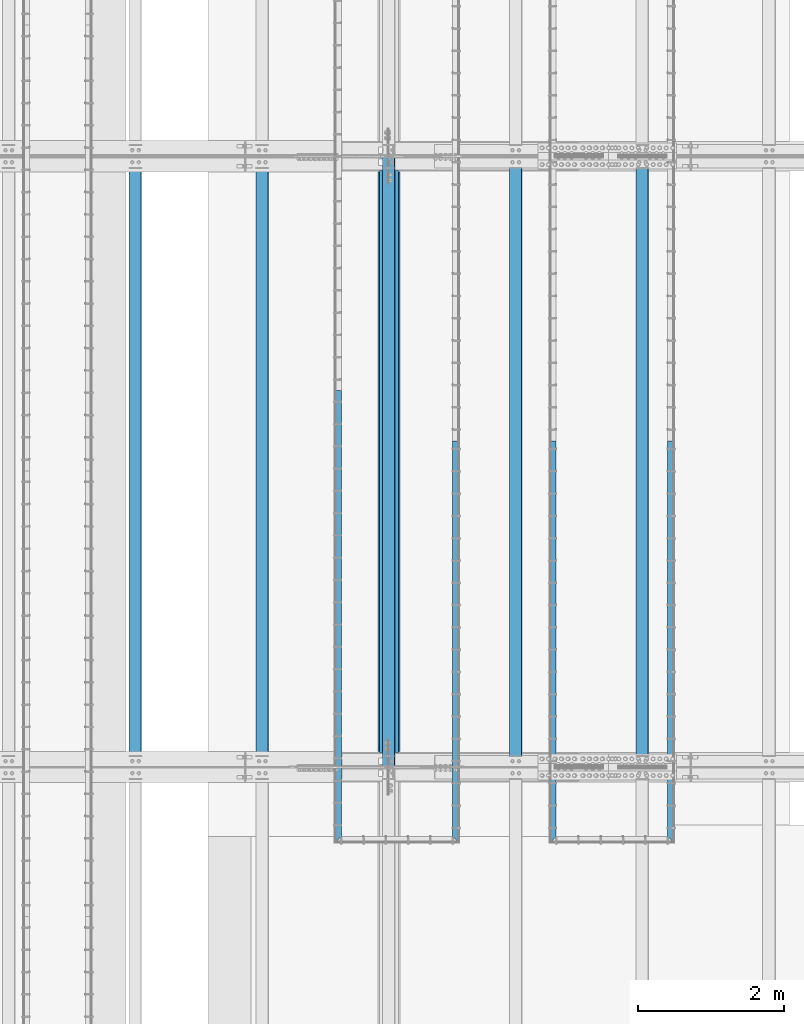
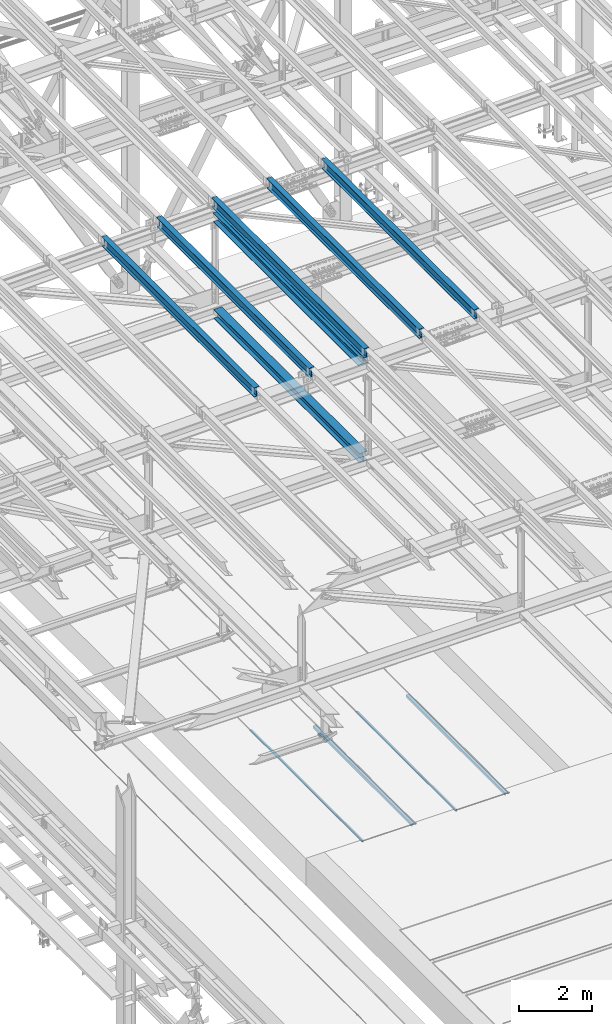
# One storey, part 1891 of 3843: 11 beams, 11 elements without a shape of their own.
"""IFC2X3 building model written with IfcOpenShell, lengths in millimetres."""

from ifc_helpers import new_model, si_unit, frame, origin_with_axes, place, context, subcontext, project, spatial, faceted_brep, material, type_object, element, aggregate, save


model = new_model("IFC2X3")

# Units and contexts
model_context = context("Model", 3, precision=1e-05, world=origin_with_axes())
body_context = subcontext(model_context, "Body", "Model", "MODEL_VIEW")
ifc_project = project(units=[si_unit("LENGTHUNIT", "METRE", prefix="MILLI"), si_unit("AREAUNIT", "SQUARE_METRE"), si_unit("VOLUMEUNIT", "CUBIC_METRE"), si_unit("MASSUNIT", "GRAM", prefix="KILO"), si_unit("TIMEUNIT", "SECOND"), si_unit("PLANEANGLEUNIT", "RADIAN"), si_unit("SOLIDANGLEUNIT", "STERADIAN"), si_unit("THERMODYNAMICTEMPERATUREUNIT", "DEGREE_CELSIUS"), si_unit("LUMINOUSINTENSITYUNIT", "LUMEN")], contexts=[model_context])

# Site, building, storey
site_placement = place(None, origin_with_axes())
site = spatial("IfcSite", under=ifc_project, at=site_placement, CompositionType="ELEMENT")
building_placement = place(site_placement, origin_with_axes())
building = spatial("IfcBuilding", under=site, at=building_placement, Name="Undefined", CompositionType="ELEMENT")
storey_placement = place(building_placement, origin_with_axes())
storey = spatial("IfcBuildingStorey", under=building, at=storey_placement, Name="Undefined", CompositionType="ELEMENT", Elevation=0.0)

# Assembly, beam
assembly_1_placement = place(storey_placement, origin_with_axes())
assembly_1 = element("IfcElementAssembly", 1, at=assembly_1_placement, inside=storey, Name="EMBED_ANGLE", AssemblyPlace="NOTDEFINED", PredefinedType="RIGID_FRAME")
ifc_material_1 = material(Name="STEEL/A36")
beam_type_1 = type_object("IfcBeamType", Name="L3-1/2X3-1/2X5/16", PredefinedType="NOTDEFINED")
beam_1_placement = place(assembly_1_placement, frame((52851.812, 71735.8227029324, 30410.15), z_axis=(0.0, 0.0, -1.0), x_axis=(0.0, -1.0, 0.0)))
beam_1 = element("IfcBeam", 2, at=beam_1_placement, type_object=beam_type_1, material=ifc_material_1, Name="EMBED_ANGLE", ObjectType="L3-1/2X3-1/2X5/16", context=body_context, shape_type="Brep", body=[
    faceted_brep([(-3.63797880709171e-12, 44.4499999999971, -44.4500000000007), (-3.63797880709171e-12, 44.4499999999971, 44.4500000000007), (5409.94572406872, 44.4500000096014, 44.4500000000007), (5409.94572406872, 44.4500000096014, -44.4500000000007), (-3.63797880709171e-12, 36.5124999999971, 44.4500000000007), (5417.88322413992, 36.5125000096305, 44.4500000000007), (-3.63797880709171e-12, 36.5124999999971, -36.5125000000007), (5417.88322413992, 36.5125000096305, -36.5125000000007), (3.63797880709171e-12, -44.4499999999971, -36.5125000000007), (5498.84572486606, -44.4499999902328, -36.5125000000007), (3.63797880709171e-12, -44.4499999999971, -44.4500000000007), (5498.84572486606, -44.4499999902328, -44.4500000000007)], [[[0, 1, 2, 3]], [[1, 4, 5, 2]], [[4, 6, 7, 5]], [[6, 8, 9, 7]], [[8, 10, 11, 9]], [[10, 0, 3, 11]], [[5, 7, 9, 11, 3, 2]], [[10, 8, 6, 4, 1, 0]]]),
])
aggregate(assembly_1, [beam_1])

assembly_2_placement = place(storey_placement, origin_with_axes())
assembly_2 = element("IfcElementAssembly", 3, at=assembly_2_placement, inside=storey, Name="EMBED_ANGLE", AssemblyPlace="NOTDEFINED", PredefinedType="RIGID_FRAME")
beam_2_placement = place(assembly_2_placement, frame((51238.9754185574, 66236.9769879788, 30410.15), z_axis=(0.0, 0.0, -1.0), x_axis=(0.0, 1.0, 0.0)))
beam_2 = element("IfcBeam", 4, at=beam_2_placement, type_object=beam_type_1, material=ifc_material_1, Name="EMBED_ANGLE", ObjectType="L3-1/2X3-1/2X5/16", context=body_context, shape_type="Brep", body=[
    faceted_brep([(88.8999999971129, 44.4500000000007, -44.4499999999971), (88.8999999965163, 44.4499999999971, 44.4500000000007), (5498.84566791133, 44.450000009776, 44.4500000000007), (5498.84566791133, 44.450000009776, -44.4500000000007), (80.9624999965163, 36.5124999999971, 44.4500000000007), (5498.84566791134, 36.512500009776, 44.4500000000007), (80.9624999971129, 36.5125000000007, -36.5124999999971), (5498.84566791134, 36.512500009776, -36.5125000000007), (3.63797880709171e-12, -44.4499999999971, -36.5125000000007), (5498.84572486606, -44.4499999902328, -36.5125000000007), (3.63797880709171e-12, -44.4499999999971, -44.4500000000007), (5498.84572486606, -44.4499999902328, -44.4500000000007)], [[[0, 1, 2, 3]], [[1, 4, 5, 2]], [[4, 6, 7, 5]], [[6, 8, 9, 7]], [[8, 10, 11, 9]], [[10, 0, 3, 11]], [[5, 7, 9, 11, 3, 2]], [[10, 8, 6, 4, 1, 0]]]),
])
aggregate(assembly_2, [beam_2])

assembly_3_placement = place(storey_placement, origin_with_axes())
assembly_3 = element("IfcElementAssembly", 5, at=assembly_3_placement, inside=storey, Name="EMBED_ANGLE", AssemblyPlace="NOTDEFINED", PredefinedType="RIGID_FRAME")
beam_3_placement = place(assembly_3_placement, frame((48298.8619292824, 66236.9765624103, 30410.15), z_axis=(0.0, 0.0, -1.0), x_axis=(0.0, 1.0, 0.0)))
beam_3 = element("IfcBeam", 6, at=beam_3_placement, type_object=beam_type_1, material=ifc_material_1, Name="EMBED_ANGLE", ObjectType="L3-1/2X3-1/2X5/16", context=body_context, shape_type="Brep", body=[
    faceted_brep([(88.9004566517688, 44.449999999968, -44.4500000000007), (88.9004566517688, 44.449999999968, 44.4500000000007), (6184.64645783564, 44.4499999976542, 44.4500000000007), (6184.64645783564, 44.4499999976542, -44.4500000000007), (80.9629571536643, 36.5124999999753, 44.4500000000007), (6184.64645783564, 36.5124999976542, 44.4500000000007), (80.9629571536643, 36.5124999999753, -36.5125000000007), (6184.64645783564, 36.5124999976542, -36.5125000000007), (0.000462273004814051, -44.4499999999971, -36.5125000000007), (6184.64645783561, -44.4500000023472, -36.5125000000007), (0.000462273004814051, -44.4499999999971, -44.4500000000007), (6184.64645783561, -44.4500000023472, -44.4500000000007)], [[[0, 1, 2, 3]], [[1, 4, 5, 2]], [[4, 6, 7, 5]], [[6, 8, 9, 7]], [[8, 10, 11, 9]], [[10, 0, 3, 11]], [[5, 7, 9, 11, 3, 2]], [[10, 8, 6, 4, 1, 0]]]),
])
aggregate(assembly_3, [beam_3])

assembly_4_placement = place(storey_placement, origin_with_axes())
assembly_4 = element("IfcElementAssembly", 7, at=assembly_4_placement, inside=storey, Name="EMBED_ANGLE", AssemblyPlace="NOTDEFINED", PredefinedType="RIGID_FRAME")
beam_4_placement = place(assembly_4_placement, frame((49911.7620576172, 71735.8227029324, 30410.15), z_axis=(0.0, 0.0, -1.0), x_axis=(0.0, -1.0, 0.0)))
beam_4 = element("IfcBeam", 8, at=beam_4_placement, type_object=beam_type_1, material=ifc_material_1, Name="EMBED_ANGLE", ObjectType="L3-1/2X3-1/2X5/16", context=body_context, shape_type="Brep", body=[
    faceted_brep([(-3.63797880709171e-12, 44.4499999999971, -44.4500000000007), (-3.63797880709171e-12, 44.4499999999971, 44.4500000000007), (5409.94572406872, 44.4500000096014, 44.4500000000007), (5409.94572406872, 44.4500000096014, -44.4500000000007), (-3.63797880709171e-12, 36.5124999999971, 44.4500000000007), (5417.88322413992, 36.5125000096305, 44.4500000000007), (-3.63797880709171e-12, 36.5124999999971, -36.5125000000007), (5417.88322413992, 36.5125000096305, -36.5125000000007), (3.63797880709171e-12, -44.4499999999971, -36.5125000000007), (5498.84572486606, -44.4499999902328, -36.5125000000007), (3.63797880709171e-12, -44.4499999999971, -44.4500000000007), (5498.84572486606, -44.4499999902328, -44.4500000000007)], [[[0, 1, 2, 3]], [[1, 4, 5, 2]], [[4, 6, 7, 5]], [[6, 8, 9, 7]], [[8, 10, 11, 9]], [[10, 0, 3, 11]], [[5, 7, 9, 11, 3, 2]], [[10, 8, 6, 4, 1, 0]]]),
])
aggregate(assembly_4, [beam_4])

assembly_5_placement = place(storey_placement, origin_with_axes())
assembly_5 = element("IfcElementAssembly", 9, at=assembly_5_placement, inside=storey, Name="BEAM", AssemblyPlace="NOTDEFINED", PredefinedType="RIGID_FRAME")
ifc_material_2 = material(Name="STEEL/A992")
beam_type_2 = type_object("IfcBeamType", Name="W12X26", PredefinedType="NOTDEFINED")
beam_5_placement = place(assembly_5_placement, frame((48993.3092623545, 67272.0720484337, 45897.8364992745), z_axis=(-0.0211520979474298, 0.0011058869996923, 0.999775657718454), x_axis=(0.0, 0.999999388232494, -0.001106135000257)))
beam_5 = element("IfcBeam", 10, at=beam_5_placement, type_object=beam_type_2, material=ifc_material_2, Name="BEAM", ObjectType="W12X26", context=body_context, shape_type="Brep", body=[
    faceted_brep([(12.7019392170769, 82.5499999998792, -155.574999999844), (12.6914056319511, 82.5499999998719, -146.049999999872), (8343.89650247573, 82.5500000000829, -146.050000009884), (8343.90703606085, 82.5500000000902, -155.575000009856), (12.6895484881388, 3.17500000001746, -146.04999999961), (8343.89464533191, 3.17500000022847, -146.050000009622), (12.3665185444988, 3.17499999995925, 146.049999999559), (8343.5716153883, 3.17500000017753, 146.049999989547), (12.3683756883402, 82.5499999998137, 146.049999999297), (8343.57347253212, 82.5500000000247, 146.049999989293), (12.3578421032144, 82.5499999998137, 155.574999999277), (8343.562938947, 82.550000000032, 155.574999989265), (12.353979244057, -82.5499999998865, 155.574999999815), (8343.55907608785, -82.5499999996755, 155.574999989803), (12.3645128291828, -82.5499999998792, 146.04999999985), (8343.56960967297, -82.5499999996682, 146.049999989838), (12.366369972995, -3.17500000002474, 146.049999999581), (8343.57146681679, -3.17499999981374, 146.049999989569), (12.6893999166205, -3.17499999996653, -146.049999999588), (8343.8944967604, -3.17499999975553, -146.0500000096), (12.6875427727937, -82.549999999821, -146.049999999319), (8343.89263961658, -82.54999999961, -146.050000009331), (12.6980763579195, -82.549999999821, -155.574999999306), (8343.9031732017, -82.54999999961, -155.57500000931)], [[[0, 1, 2, 3]], [[1, 4, 5, 2]], [[4, 6, 7, 5]], [[6, 8, 9, 7]], [[8, 10, 11, 9]], [[10, 12, 13, 11]], [[12, 14, 15, 13]], [[14, 16, 17, 15]], [[16, 18, 19, 17]], [[18, 20, 21, 19]], [[20, 22, 23, 21]], [[22, 0, 3, 23]], [[5, 7, 9, 11, 13, 15, 17, 19, 21, 23, 3, 2]], [[22, 20, 18, 16, 14, 12, 10, 8, 6, 4, 1, 0]]]),
])
aggregate(assembly_5, [beam_5])

assembly_6_placement = place(storey_placement, origin_with_axes())
assembly_6 = element("IfcElementAssembly", 11, at=assembly_6_placement, inside=storey, Name="BEAM", AssemblyPlace="NOTDEFINED", PredefinedType="RIGID_FRAME")
beam_6_placement = place(assembly_6_placement, frame((52460.4094458689, 67272.1092467259, 45983.0164319707), z_axis=(-0.0211520981778377, 0.00134498899952451, 0.999775364643111), x_axis=(0.0, 0.999999095040495, -0.00134533200005457)))
beam_6 = element("IfcBeam", 12, at=beam_6_placement, type_object=beam_type_2, material=ifc_material_2, Name="BEAM", ObjectType="W12X26", context=body_context, shape_type="Brep", body=[
    faceted_brep([(12.7023352605465, 82.550000000112, -155.57499999967), (12.689551317424, 82.5499999996828, -146.04999999985), (8343.89709015501, 82.5500000202519, -146.049999989009), (8343.90990119209, 82.5500000202373, -155.574999988996), (12.6872908958176, 3.17499999984284, -146.049999999908), (8343.89482973338, 3.17500002041197, -146.049999989053), (12.2944190916023, 3.17500000019936, 146.049999999945), (8343.50195792918, 3.17500002076849, 146.0500000108), (12.2966795132234, 82.5500000000538, 146.049999999996), (8343.5042183508, 82.5500000206084, 146.050000010844), (12.2838684761373, 82.5500000000538, 155.574999999997), (8343.4914073137, 82.5500000206303, 155.575000010846), (12.2791667991551, -82.5499999996173, 155.574999999888), (8343.48670563672, -82.5499999790482, 155.575000010729), (12.2919778362557, -82.5499999996246, 146.049999999879), (8343.49951667382, -82.5499999790627, 146.050000010735), (12.2942382578767, -3.17499999977736, 146.049999999945), (8343.50177709546, -3.17499997922278, 146.050000010793), (12.687110062092, -3.17500000014843, -146.049999999908), (8343.89464889963, -3.1749999795793, -146.04999998906), (12.6848496404564, -82.5499999999884, -146.049999999959), (8343.89243466449, -82.5500000001557, -146.049999991803), (12.6976871889201, -82.5499999995736, -155.574999999961), (8343.90519951511, -82.5499999794265, -155.574999989105)], [[[0, 1, 2, 3]], [[1, 4, 5, 2]], [[4, 6, 7, 5]], [[6, 8, 9, 7]], [[8, 10, 11, 9]], [[10, 12, 13, 11]], [[12, 14, 15, 13]], [[14, 16, 17, 15]], [[16, 18, 19, 17]], [[18, 20, 21, 19]], [[20, 22, 23, 21]], [[22, 0, 3, 23]], [[5, 7, 9, 11, 13, 15, 17, 19, 21, 23, 3, 2]], [[22, 20, 18, 16, 14, 12, 10, 8, 6, 4, 1, 0]]]),
])
aggregate(assembly_6, [beam_6])

assembly_7_placement = place(storey_placement, origin_with_axes())
assembly_7 = element("IfcElementAssembly", 13, at=assembly_7_placement, inside=storey, Name="BEAM", AssemblyPlace="NOTDEFINED", PredefinedType="RIGID_FRAME")
beam_7_placement = place(assembly_7_placement, frame((50726.8592623405, 67272.0903653706, 45940.703009165), z_axis=(-0.0211520978152839, 0.00122362399946723, 0.99977552055565), x_axis=(2.79999998903554e-08, 0.999999251036562, -0.00122389800004501)))
beam_7 = element("IfcBeam", 14, at=beam_7_placement, type_object=beam_type_2, material=ifc_material_2, Name="BEAM", ObjectType="W12X26", context=body_context, shape_type="Brep", body=[
    faceted_brep([(12.7021740270138, 82.5499999997846, -155.57500000007), (12.6904892753955, 82.5499999993772, -146.049999999537), (8343.89674809582, 82.5499999787862, -146.049999973642), (8343.90838416996, 82.5500000165994, -155.574999981953), (12.6884366350714, 3.17499999953725, -146.049999999501), (8343.89464533191, 3.17500000022847, -146.050000009622), (12.3310155737126, 3.17500000051223, 146.049999999559), (8343.53725543368, 3.17500001775625, 146.050000017116), (12.3330682140513, 82.5500000003522, 146.049999999515), (8343.539308074, 82.5500000176035, 146.050000017065), (12.3214131794375, 82.5500000003813, 155.57499999948), (8343.52765303939, 82.5500000176398, 155.575000017045), (12.3171436875709, -82.5499999992899, 155.574999999575), (8343.52338354754, -82.5499999820386, 155.575000017132), (12.3287987221847, -82.549999999319, 146.049999999595), (8343.53503858214, -82.5499999820677, 146.05000001716), (12.3308513625088, -3.17499999947904, 146.049999999559), (8343.53709122246, -3.17499998222047, 146.050000017116), (12.688272423853, -3.17500000044674, -146.049999999501), (8343.8944967604, -3.17499999975553, -146.0500000096), (12.6862197835289, -82.5500000002867, -146.049999999464), (8343.89243466449, -82.5500000001557, -146.049999991803), (12.6978455112549, -82.549999999952, -155.574999999837), (8343.90411467811, -82.5499999830718, -155.574999981858)], [[[0, 1, 2, 3]], [[1, 4, 5, 2]], [[4, 6, 7, 5]], [[6, 8, 9, 7]], [[8, 10, 11, 9]], [[10, 12, 13, 11]], [[12, 14, 15, 13]], [[14, 16, 17, 15]], [[16, 18, 19, 17]], [[18, 20, 21, 19]], [[20, 22, 23, 21]], [[22, 0, 3, 23]], [[5, 7, 9, 11, 13, 15, 17, 19, 21, 23, 3, 2]], [[22, 20, 18, 16, 14, 12, 10, 8, 6, 4, 1, 0]]]),
])
aggregate(assembly_7, [beam_7])

assembly_8_placement = place(storey_placement, origin_with_axes())
assembly_8 = element("IfcElementAssembly", 15, at=assembly_8_placement, inside=storey, Name="BEAM", AssemblyPlace="NOTDEFINED", PredefinedType="RIGID_FRAME")
beam_8_placement = place(assembly_8_placement, frame((47259.7594457599, 67272.052096395, 45854.4279800656), z_axis=(-0.0211520981419525, 0.000977640000332028, 0.999775791347352), x_axis=(-2.20000000263604e-08, 0.999999521894796, -0.000977859999897309)))
beam_8 = element("IfcBeam", 16, at=beam_8_placement, type_object=beam_type_2, material=ifc_material_2, Name="BEAM", ObjectType="W12X26", context=body_context, shape_type="Brep", body=[
    faceted_brep([(12.701685369233, 82.5499999992826, -155.574999999793), (12.6924033689284, 82.5499999997628, -146.050000000309), (8343.89638659473, 82.5500000205211, -146.049999998155), (8343.90569862744, 82.5500000205066, -155.574999998171), (12.6907598465041, 3.17499999989377, -146.050000000301), (8343.89474307231, 3.1750000206448, -146.049999998148), (12.4051908436813, 3.17500000014843, 146.050000000316), (8343.60917406947, 3.17500002089218, 146.050000002469), (12.4068343661056, 82.5500000000175, 146.050000000316), (8343.61081759189, 82.5500000207685, 146.050000002469), (12.3975223333982, 82.5500000000247, 155.575000000332), (8343.60150555919, 82.5500000207758, 155.575000002493), (12.3941038067424, -82.5499999997046, 155.575000000332), (8343.59808703253, -82.5499999789608, 155.575000002485), (12.4034158394352, -82.5499999997119, 146.050000000309), (8343.60739906522, -82.5499999789608, 146.050000002462), (12.405059361874, -3.17499999983556, 146.050000000316), (8343.60904258766, -3.17499997909181, 146.050000002462), (12.6906283647113, -3.1750000000975, -146.050000000301), (8343.89464889963, -3.1749999795793, -146.04999998906), (12.6889848422725, -82.5499999999665, -146.050000000316), (8343.89298212373, -82.5500000221145, -146.050000010255), (12.6983264118026, -82.5500000004176, -155.574999999502), (8343.90223456245, -82.5500000011962, -155.575000014913)], [[[0, 1, 2, 3]], [[1, 4, 5, 2]], [[4, 6, 7, 5]], [[6, 8, 9, 7]], [[8, 10, 11, 9]], [[10, 12, 13, 11]], [[12, 14, 15, 13]], [[14, 16, 17, 15]], [[16, 18, 19, 17]], [[18, 20, 21, 19]], [[20, 22, 23, 21]], [[22, 0, 3, 23]], [[5, 7, 9, 11, 13, 15, 17, 19, 21, 23, 3, 2]], [[22, 20, 18, 16, 14, 12, 10, 8, 6, 4, 1, 0]]]),
])
aggregate(assembly_8, [beam_8])

assembly_9_placement = place(storey_placement, origin_with_axes())
assembly_9 = element("IfcElementAssembly", 17, at=assembly_9_placement, inside=storey, Name="BEAM", AssemblyPlace="NOTDEFINED", PredefinedType="RIGID_FRAME")
beam_9_placement = place(assembly_9_placement, frame((45526.2092623303, 67272.0301769835, 45810.4000140868), z_axis=(-0.0211520984153467, 0.000836747000153993, 0.999775919187437), x_axis=(0.0, 0.999999649769842, -0.000836934999807779)))
beam_9 = element("IfcBeam", 18, at=beam_9_placement, type_object=beam_type_2, material=ifc_material_2, Name="BEAM", ObjectType="W12X26", context=body_context, shape_type="Brep", body=[
    faceted_brep([(12.7014658721164, 82.5500000003449, -155.575000000077), (12.6934958470665, 82.5500000003231, -146.050000000061), (8343.89638659473, 82.5500000205211, -146.049999998155), (8343.90438362172, 82.5499999997119, -155.574999969955), (12.6920906762243, 3.1750000004613, -146.050000000214), (8343.89500842584, 3.17499999982101, -146.049999970084), (12.4476765748113, 3.17499999954453, 146.050000000323), (8343.65059432443, 3.17499999890424, 146.050000030453), (12.4490817456535, 82.549999999399, 146.050000000476), (8343.65199949527, 82.549999998766, 146.050000030598), (12.4411117206037, 82.5499999993772, 155.575000000492), (8343.64402947023, 82.5499999987369, 155.575000030622), (12.4381889652577, -82.5500000003376, 155.575000000186), (8343.64110671487, -82.5500000009706, 155.575000030301), (12.4461589903221, -82.5500000003085, 146.050000000163), (8343.64907673994, -82.5500000009488, 146.050000030285), (12.4475641611498, -3.17500000044674, 146.050000000316), (8343.65048191076, -3.17500000107975, 146.050000030438), (12.6919782625482, -3.17499999952997, -146.050000000228), (8343.89487530109, -3.1750000003085, -146.049999991643), (12.6905730917206, -82.5499999993845, -146.050000000374), (8343.89352054658, -82.5499999996246, -146.050000027215), (12.6985431167705, -82.5499999993626, -155.575000000397), (8343.90149992992, -82.5500000001484, -155.575000012577)], [[[0, 1, 2, 3]], [[1, 4, 5, 2]], [[4, 6, 7, 5]], [[6, 8, 9, 7]], [[8, 10, 11, 9]], [[10, 12, 13, 11]], [[12, 14, 15, 13]], [[14, 16, 17, 15]], [[16, 18, 19, 17]], [[18, 20, 21, 19]], [[20, 22, 23, 21]], [[22, 0, 3, 23]], [[5, 7, 9, 11, 13, 15, 17, 19, 21, 23, 3, 2]], [[22, 20, 18, 16, 14, 12, 10, 8, 6, 4, 1, 0]]]),
])
aggregate(assembly_9, [beam_9])

assembly_10_placement = place(storey_placement, origin_with_axes())
assembly_10 = element("IfcElementAssembly", 19, at=assembly_10_placement, inside=storey, Name="BEAM", AssemblyPlace="NOTDEFINED", PredefinedType="RIGID_FRAME")
beam_type_3 = type_object("IfcBeamType", Name="W12X65", PredefinedType="NOTDEFINED")
beam_10_placement = place(assembly_10_placement, frame((48996.6, 67271.9, 45545.3887933268), z_axis=(0.0, 0.00110613500025647, 0.999999388232494), x_axis=(0.0, 0.999999388232494, -0.001106135000257)))
beam_10 = element("IfcBeam", 20, at=beam_10_placement, type_object=beam_type_3, material=ifc_material_2, Name="BEAM", ObjectType="W12X65", context=body_context, shape_type="Brep", body=[
    faceted_brep([(212.895461209104, 152.400000000001, -153.987499999908), (212.87790130511, 152.400000000001, -138.112499999937), (8144.03275340708, 152.400000000001, -138.112500009469), (8144.05031331106, 152.400000000001, -153.98750000944), (212.87790130511, 4.76249999999709, -138.112499999937), (8144.03275340708, 4.76249999999709, -138.112500009469), (212.57235897574, 4.76249999999709, 138.112499999428), (8143.72721107771, 4.76249999999709, 138.112499989889), (212.57235897574, 152.400000000001, 138.112499999428), (8143.72721107771, 152.400000000001, 138.112499989889), (212.55479907176, 152.400000000001, 153.987499999384), (8143.70965117372, 152.400000000001, 153.987499989853), (212.55479907176, -152.400000000001, 153.987499999384), (8143.70965117372, -152.400000000001, 153.987499989853), (212.57235897574, -152.400000000001, 138.112499999428), (8143.72721107771, -152.400000000001, 138.112499989889), (212.57235897574, -4.76249999999709, 138.112499999428), (8143.72721107771, -4.76249999999709, 138.112499989889), (212.87790130511, -4.76249999999709, -138.112499999937), (8144.03275340708, -4.76249999999709, -138.112500009469), (212.87790130511, -152.400000000001, -138.112499999937), (8144.03275340708, -152.400000000001, -138.112500009469), (212.895461209104, -152.400000000001, -153.987499999908), (8144.05031331106, -152.400000000001, -153.98750000944)], [[[0, 1, 2, 3]], [[1, 4, 5, 2]], [[4, 6, 7, 5]], [[6, 8, 9, 7]], [[8, 10, 11, 9]], [[10, 12, 13, 11]], [[12, 14, 15, 13]], [[14, 16, 17, 15]], [[16, 18, 19, 17]], [[18, 20, 21, 19]], [[20, 22, 23, 21]], [[22, 0, 3, 23]], [[5, 7, 9, 11, 13, 15, 17, 19, 21, 23, 3, 2]], [[22, 20, 18, 16, 14, 12, 10, 8, 6, 4, 1, 0]]]),
])
aggregate(assembly_10, [beam_10])

assembly_11_placement = place(storey_placement, origin_with_axes())
assembly_11 = element("IfcElementAssembly", 21, at=assembly_11_placement, inside=storey, Name="BEAM", AssemblyPlace="NOTDEFINED", PredefinedType="RIGID_FRAME")
beam_type_4 = type_object("IfcBeamType", Name="W12X53", PredefinedType="NOTDEFINED")
beam_11_placement = place(assembly_11_placement, frame((48996.6, 67271.9, 42307.697012333), z_axis=(0.0, 0.00110613500025647, 0.999999388232494), x_axis=(0.0, 0.999999388232494, -0.001106135000257)))
beam_11 = element("IfcBeam", 22, at=beam_11_placement, type_object=beam_type_4, material=ifc_material_2, Name="BEAM", ObjectType="W12X53", context=body_context, shape_type="Brep", body=[
    faceted_brep([(198.606174801404, 127.0, -152.400000000795), (198.590372916631, 127.0, -138.112500000781), (8158.32024106631, 127.0, -138.112500028263), (8158.33604295108, 127.0, -152.400000028276), (198.590372916631, 4.76249999999709, -138.112500000781), (8158.32024106631, 4.76249999999709, -138.112500028263), (198.284869811236, 4.76249999999709, 138.112499999421), (8158.01473796091, 4.76249999999709, 138.11249997194), (198.284869811236, 127.0, 138.112499999421), (8158.01473796091, 127.0, 138.11249997194), (198.269067926478, 127.0, 152.399999999427), (8157.99893607615, 127.0, 152.399999971945), (198.269067926478, -127.0, 152.399999999427), (8157.99893607615, -127.0, 152.399999971945), (198.284869811236, -127.0, 138.112499999421), (8158.01473796091, -127.0, 138.11249997194), (198.284869811236, -4.76249999999709, 138.112499999421), (8158.01473796091, -4.76249999999709, 138.11249997194), (198.590372916631, -4.76249999999709, -138.112500000781), (8158.32024106631, -4.76249999999709, -138.112500028263), (198.590372916631, -127.0, -138.112500000781), (8158.32024106631, -127.0, -138.112500028263), (198.606174801404, -127.0, -152.400000000795), (8158.33604295108, -127.0, -152.400000028276)], [[[0, 1, 2, 3]], [[1, 4, 5, 2]], [[4, 6, 7, 5]], [[6, 8, 9, 7]], [[8, 10, 11, 9]], [[10, 12, 13, 11]], [[12, 14, 15, 13]], [[14, 16, 17, 15]], [[16, 18, 19, 17]], [[18, 20, 21, 19]], [[20, 22, 23, 21]], [[22, 0, 3, 23]], [[5, 7, 9, 11, 13, 15, 17, 19, 21, 23, 3, 2]], [[22, 20, 18, 16, 14, 12, 10, 8, 6, 4, 1, 0]]]),
])
aggregate(assembly_11, [beam_11])

save(model, "model.ifc")
